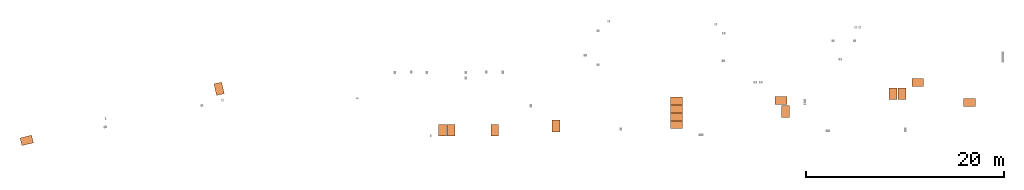
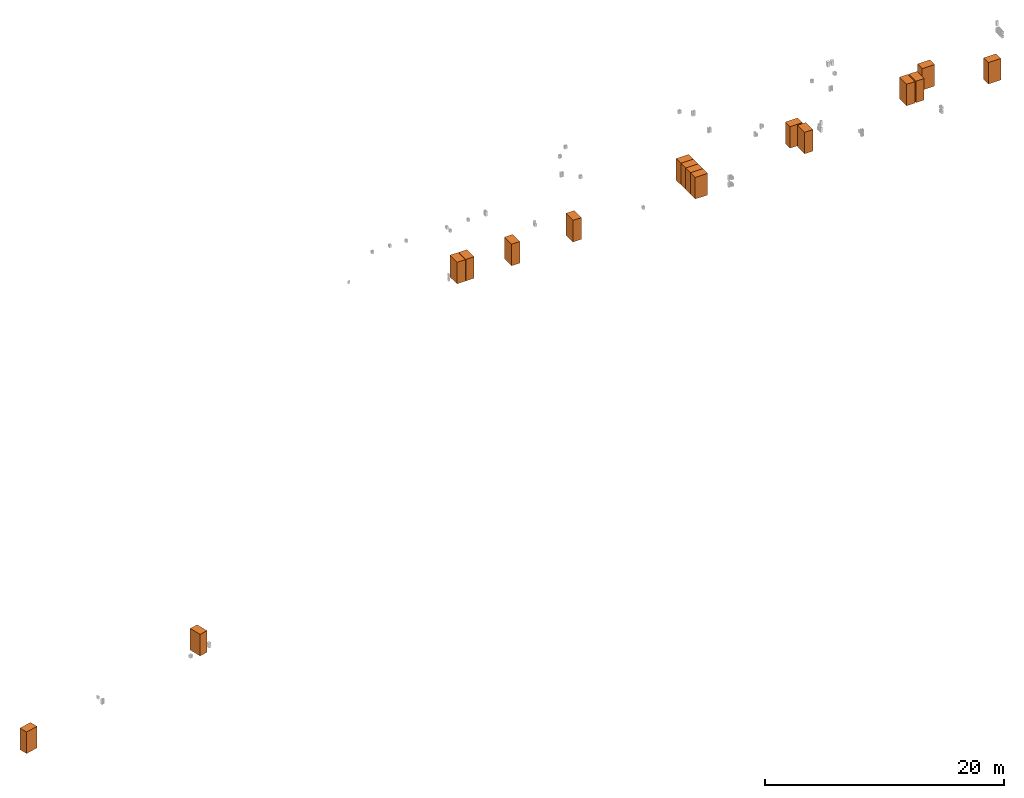
# Not in any storey, part 1 of 4: 16 proxies.
"""IFC2X3 model written with IfcOpenShell, lengths in millimetres."""

from ifc_helpers import new_model, si_unit, derived_unit, direction, frame, origin, place, context, subcontext, project, spatial, faceted_brep, type_object, element, save


model = new_model("IFC2X3")

# Units and contexts
model_context = context("Model", 3, precision=0.01, world=origin(), true_north=direction((6.12303176911189e-17, 1.0)))
body_context = subcontext(model_context, "Body", "Model", "MODEL_VIEW")
ifc_project = project(units=[si_unit("LENGTHUNIT", "METRE", prefix="MILLI"), si_unit("AREAUNIT", "SQUARE_METRE"), si_unit("VOLUMEUNIT", "CUBIC_METRE"), si_unit("PLANEANGLEUNIT", "RADIAN"), si_unit("MASSUNIT", "GRAM", prefix="KILO"), derived_unit("MASSDENSITYUNIT", [(si_unit("MASSUNIT", "GRAM", prefix="KILO"), 1), (si_unit("LENGTHUNIT", "METRE"), -3)]), derived_unit("MOMENTOFINERTIAUNIT", [(si_unit("LENGTHUNIT", "METRE"), 4)]), si_unit("TIMEUNIT", "SECOND"), si_unit("FREQUENCYUNIT", "HERTZ"), si_unit("THERMODYNAMICTEMPERATUREUNIT", "DEGREE_CELSIUS"), derived_unit("THERMALTRANSMITTANCEUNIT", [(si_unit("MASSUNIT", "GRAM", prefix="KILO"), 1), (si_unit("THERMODYNAMICTEMPERATUREUNIT", "KELVIN"), -1), (si_unit("TIMEUNIT", "SECOND"), -3)]), derived_unit("VOLUMETRICFLOWRATEUNIT", [(si_unit("LENGTHUNIT", "METRE"), 3), (si_unit("TIMEUNIT", "SECOND"), -1)]), derived_unit("MASSFLOWRATEUNIT", [(si_unit("MASSUNIT", "GRAM", prefix="KILO"), 1), (si_unit("TIMEUNIT", "SECOND"), -1)]), derived_unit("ROTATIONALFREQUENCYUNIT", [(si_unit("TIMEUNIT", "SECOND"), -1)]), si_unit("ELECTRICCURRENTUNIT", "AMPERE"), si_unit("ELECTRICVOLTAGEUNIT", "VOLT"), si_unit("POWERUNIT", "WATT"), si_unit("FORCEUNIT", "NEWTON", prefix="KILO"), si_unit("ILLUMINANCEUNIT", "LUX"), si_unit("LUMINOUSFLUXUNIT", "LUMEN"), si_unit("LUMINOUSINTENSITYUNIT", "CANDELA"), derived_unit("USERDEFINED", [(si_unit("MASSUNIT", "GRAM", prefix="KILO"), -1), (si_unit("LENGTHUNIT", "METRE"), -2), (si_unit("TIMEUNIT", "SECOND"), 3), (si_unit("LUMINOUSFLUXUNIT", "LUMEN"), 1)]), derived_unit("LINEARVELOCITYUNIT", [(si_unit("LENGTHUNIT", "METRE"), 1), (si_unit("TIMEUNIT", "SECOND"), -1)]), si_unit("PRESSUREUNIT", "PASCAL"), derived_unit("USERDEFINED", [(si_unit("LENGTHUNIT", "METRE"), -2), (si_unit("MASSUNIT", "GRAM", prefix="KILO"), 1), (si_unit("TIMEUNIT", "SECOND"), -2)]), derived_unit("LINEARFORCEUNIT", [(si_unit("MASSUNIT", "GRAM", prefix="KILO"), 1), (si_unit("LENGTHUNIT", "METRE"), 1), (si_unit("TIMEUNIT", "SECOND"), -2), (si_unit("LENGTHUNIT", "METRE"), -1)]), derived_unit("PLANARFORCEUNIT", [(si_unit("MASSUNIT", "GRAM", prefix="KILO"), 1), (si_unit("LENGTHUNIT", "METRE"), 1), (si_unit("TIMEUNIT", "SECOND"), -2), (si_unit("LENGTHUNIT", "METRE"), -2)])], contexts=[model_context])

# Site
site_placement = place(None, frame((0.0, -0.00077364408347762, 0.0)))
site = spatial("IfcSite", under=ifc_project, at=site_placement, CompositionType="ELEMENT")

# Proxies
building_element_proxy_type_1 = type_object("IfcBuildingElementProxyType", PredefinedType="NOTDEFINED")
proxy_1_placement = place(site_placement, frame((-6495.69993250786, 11805.728165958, -4200.0)))
element("IfcBuildingElementProxy", 1, at=proxy_1_placement, inside=site, type_object=building_element_proxy_type_1, context=body_context, shape_type="Brep", body=[
    faceted_brep([(871.974554424364, 966.709812850611, 0.0), (777.239295998118, 1355.32946084967, 0.0), (871.974554424364, 966.709812850611, 2200.0), (777.239295998117, 1355.32946084967, 2200.0), (94.7352584262477, 777.239295998111, 2200.0), (0.0, 1165.85894399717, 2200.0), (94.7352584262477, 777.239295998109, 0.0), (0.0, 1165.85894399717, 0.0)], [[[0, 1, 2]], [[3, 2, 1]], [[4, 5, 6]], [[7, 6, 5]], [[7, 5, 1]], [[3, 1, 5]], [[0, 2, 6]], [[4, 6, 2]], [[5, 4, 3]], [[2, 3, 4]], [[7, 1, 6]], [[0, 6, 1]]]),
    faceted_brep([(1061.44507127686, 189.470516852489, 0.0), (871.974554424365, 966.709812850609, 0.0), (1061.44507127686, 189.470516852489, 2200.0), (871.974554424365, 966.709812850611, 2200.0), (284.205775278742, 0.0, 2200.0), (94.7352584262466, 777.23929599812, 2200.0), (284.205775278743, 0.0, 0.0), (94.7352584262477, 777.23929599812, 0.0)], [[[0, 1, 2]], [[3, 2, 1]], [[4, 5, 6]], [[7, 6, 5]], [[7, 5, 1]], [[3, 1, 5]], [[0, 2, 6]], [[4, 6, 2]], [[5, 4, 3]], [[2, 3, 4]], [[7, 1, 6]], [[0, 6, 1]]]),
])
building_element_proxy_type_2 = type_object("IfcBuildingElementProxyType", PredefinedType="NOTDEFINED")
proxy_2_placement = place(site_placement, frame((-26068.6076268077, 6738.45006749214, -4200.0)))
element("IfcBuildingElementProxy", 2, at=proxy_2_placement, inside=site, type_object=building_element_proxy_type_2, context=body_context, shape_type="Brep", body=[
    faceted_brep([(0.0, 777.239295998119, 0.0), (0.0, 777.239295998117, 2200.0), (388.619647999063, 871.974554424364, 0.0), (388.619647999063, 871.974554424364, 2200.0), (578.090164851556, 94.7352584262477, 0.0), (578.090164851552, 94.7352584262466, 2200.0), (189.470516852502, 0.0, 0.0), (189.470516852502, 0.0, 2200.0)], [[[0, 1, 2]], [[3, 2, 1]], [[4, 5, 6]], [[7, 6, 5]], [[7, 1, 6]], [[0, 6, 1]], [[4, 2, 5]], [[3, 5, 2]], [[1, 7, 3]], [[5, 3, 7]], [[0, 2, 6]], [[4, 6, 2]]]),
    faceted_brep([(388.619647999067, 871.974554424366, 0.0), (388.619647999059, 871.974554424364, 2200.0), (1165.85894399719, 1061.44507127686, 0.0), (1165.85894399719, 1061.44507127686, 2200.0), (1355.32946084967, 284.205775278743, 0.0), (1355.32946084967, 284.205775278743, 2200.0), (578.090164851565, 94.7352584262488, 0.0), (578.090164851561, 94.7352584262466, 2200.0)], [[[0, 1, 2]], [[3, 2, 1]], [[4, 5, 6]], [[7, 6, 5]], [[7, 1, 6]], [[0, 6, 1]], [[4, 2, 5]], [[3, 5, 2]], [[1, 7, 3]], [[5, 3, 7]], [[0, 2, 6]], [[4, 6, 2]]]),
])
building_element_proxy_type_3 = type_object("IfcBuildingElementProxyType", PredefinedType="NOTDEFINED")
proxy_3_placement = place(site_placement, frame((17049.99, 7700.0, 28400.0)))
element("IfcBuildingElementProxy", 3, at=proxy_3_placement, inside=site, type_object=building_element_proxy_type_3, context=body_context, shape_type="Brep", body=[
    faceted_brep([(0.0, 0.0, 2200.0), (0.0, 400.0, 2200.0), (0.0, 0.0, 0.0), (0.0, 400.0, 0.0), (800.0, 0.0, 0.0), (800.0, 400.0, 0.0), (800.0, 0.0, 2200.0), (800.0, 400.0, 2200.0)], [[[0, 1, 2]], [[3, 2, 1]], [[4, 5, 6]], [[7, 6, 5]], [[4, 6, 2]], [[0, 2, 6]], [[3, 1, 5]], [[7, 5, 1]], [[0, 6, 1]], [[7, 1, 6]], [[3, 5, 2]], [[4, 2, 5]]]),
    faceted_brep([(0.0, 400.0, 2200.0), (0.0, 1200.0, 2200.0), (0.0, 400.0, 0.0), (0.0, 1200.0, 0.0), (800.0, 400.0, 0.0), (800.0, 1200.0, 0.0), (800.0, 400.0, 2200.0), (800.0, 1200.0, 2200.0)], [[[0, 1, 2]], [[3, 2, 1]], [[4, 5, 6]], [[7, 6, 5]], [[4, 6, 2]], [[0, 2, 6]], [[3, 1, 5]], [[7, 5, 1]], [[0, 6, 1]], [[7, 1, 6]], [[3, 5, 2]], [[4, 2, 5]]]),
])
building_element_proxy_type_4 = type_object("IfcBuildingElementProxyType", PredefinedType="NOTDEFINED")
proxy_4_placement = place(site_placement, frame((21470.01, 7700.0, 28400.0)))
element("IfcBuildingElementProxy", 4, at=proxy_4_placement, inside=site, type_object=building_element_proxy_type_4, context=body_context, shape_type="Brep", body=[
    faceted_brep([(0.0, 0.0, 2200.0), (0.0, 400.0, 2200.0), (0.0, 0.0, 0.0), (0.0, 400.0, 0.0), (800.0, 0.0, 0.0), (800.0, 400.0, 0.0), (800.0, 0.0, 2200.0), (800.0, 400.0, 2200.0)], [[[0, 1, 2]], [[3, 2, 1]], [[4, 5, 6]], [[7, 6, 5]], [[4, 6, 2]], [[0, 2, 6]], [[3, 1, 5]], [[7, 5, 1]], [[0, 6, 1]], [[7, 1, 6]], [[3, 5, 2]], [[4, 2, 5]]]),
    faceted_brep([(0.0, 400.0, 2200.0), (0.0, 1200.0, 2200.0), (0.0, 400.0, 0.0), (0.0, 1200.0, 0.0), (800.0, 400.0, 0.0), (800.0, 1200.0, 0.0), (800.0, 400.0, 2200.0), (800.0, 1200.0, 2200.0)], [[[0, 1, 2]], [[3, 2, 1]], [[4, 5, 6]], [[7, 6, 5]], [[4, 6, 2]], [[0, 2, 6]], [[3, 1, 5]], [[7, 5, 1]], [[0, 6, 1]], [[7, 1, 6]], [[3, 5, 2]], [[4, 2, 5]]]),
])
building_element_proxy_type_5 = type_object("IfcBuildingElementProxyType", PredefinedType="NOTDEFINED")
proxy_5_placement = place(site_placement, frame((16199.99, 7700.0, 28400.0)))
element("IfcBuildingElementProxy", 5, at=proxy_5_placement, inside=site, type_object=building_element_proxy_type_5, context=body_context, shape_type="Brep", body=[
    faceted_brep([(0.0, 0.0, 2200.0), (0.0, 400.0, 2200.0), (0.0, 0.0, 0.0), (0.0, 400.0, 0.0), (800.0, 0.0, 0.0), (800.0, 400.0, 0.0), (800.0, 0.0, 2200.0), (800.0, 400.0, 2200.0)], [[[0, 1, 2]], [[3, 2, 1]], [[4, 5, 6]], [[7, 6, 5]], [[4, 6, 2]], [[0, 2, 6]], [[3, 1, 5]], [[7, 5, 1]], [[0, 6, 1]], [[7, 1, 6]], [[3, 5, 2]], [[4, 2, 5]]]),
    faceted_brep([(0.0, 400.0, 2200.0), (0.0, 1200.0, 2200.0), (0.0, 400.0, 0.0), (0.0, 1200.0, 0.0), (800.0, 400.0, 0.0), (800.0, 1200.0, 0.0), (800.0, 400.0, 2200.0), (800.0, 1200.0, 2200.0)], [[[0, 1, 2]], [[3, 2, 1]], [[4, 5, 6]], [[7, 6, 5]], [[4, 6, 2]], [[0, 2, 6]], [[3, 1, 5]], [[7, 5, 1]], [[0, 6, 1]], [[7, 1, 6]], [[3, 5, 2]], [[4, 2, 5]]]),
])
building_element_proxy_type_6 = type_object("IfcBuildingElementProxyType", PredefinedType="NOTDEFINED")
proxy_6_placement = place(site_placement, frame((69205.06, 10700.01, 28400.0)))
element("IfcBuildingElementProxy", 6, at=proxy_6_placement, inside=site, type_object=building_element_proxy_type_6, context=body_context, shape_type="Brep", body=[
    faceted_brep([(0.0, 800.0, 0.0), (0.0, 800.0, 2200.0), (400.0, 800.0, 0.0), (400.0, 800.0, 2200.0), (400.0, 0.0, 0.0), (400.0, 0.0, 2200.0), (0.0, 0.0, 0.0), (0.0, 0.0, 2200.0)], [[[0, 1, 2]], [[3, 2, 1]], [[4, 5, 6]], [[7, 6, 5]], [[7, 1, 6]], [[0, 6, 1]], [[4, 2, 5]], [[3, 5, 2]], [[7, 5, 1]], [[3, 1, 5]], [[0, 2, 6]], [[4, 6, 2]]]),
    faceted_brep([(400.0, 800.0, 0.0), (400.0, 800.0, 2200.0), (1200.0, 800.0, 0.0), (1200.0, 800.0, 2200.0), (1200.0, 0.0, 0.0), (1200.0, 0.0, 2200.0), (400.0, 0.0, 0.0), (400.0, 0.0, 2200.0)], [[[0, 1, 2]], [[3, 2, 1]], [[4, 5, 6]], [[7, 6, 5]], [[7, 1, 6]], [[0, 6, 1]], [[4, 2, 5]], [[3, 5, 2]], [[7, 5, 1]], [[3, 1, 5]], [[0, 2, 6]], [[4, 6, 2]]]),
])
building_element_proxy_type_7 = type_object("IfcBuildingElementProxyType", PredefinedType="NOTDEFINED")
proxy_7_placement = place(site_placement, frame((39620.11, 9250.0, 28400.0)))
element("IfcBuildingElementProxy", 7, at=proxy_7_placement, inside=site, type_object=building_element_proxy_type_7, context=body_context, shape_type="Brep", body=[
    faceted_brep([(1200.0, 0.0, 0.0), (1200.0, 0.0, 2200.0), (800.0, 0.0, 0.0), (800.0, 0.0, 2200.0), (800.0, 800.0, 0.0), (800.0, 800.0, 2200.0), (1200.0, 800.0, 0.0), (1200.0, 800.0, 2200.0)], [[[0, 1, 2]], [[3, 2, 1]], [[4, 5, 6]], [[7, 6, 5]], [[0, 6, 1]], [[7, 1, 6]], [[3, 5, 2]], [[4, 2, 5]], [[3, 1, 5]], [[7, 5, 1]], [[4, 6, 2]], [[0, 2, 6]]]),
    faceted_brep([(800.0, 0.0, 0.0), (800.0, 0.0, 2200.0), (0.0, 0.0, 0.0), (0.0, 0.0, 2200.0), (0.0, 800.0, 0.0), (0.0, 800.0, 2200.0), (800.0, 800.0, 0.0), (800.0, 800.0, 2200.0)], [[[0, 1, 2]], [[3, 2, 1]], [[4, 5, 6]], [[7, 6, 5]], [[0, 6, 1]], [[7, 1, 6]], [[3, 5, 2]], [[4, 2, 5]], [[3, 1, 5]], [[7, 5, 1]], [[4, 6, 2]], [[0, 2, 6]]]),
])
building_element_proxy_type_8 = type_object("IfcBuildingElementProxyType", PredefinedType="NOTDEFINED")
proxy_8_placement = place(site_placement, frame((39620.11, 10050.0, 28400.0)))
element("IfcBuildingElementProxy", 8, at=proxy_8_placement, inside=site, type_object=building_element_proxy_type_8, context=body_context, shape_type="Brep", body=[
    faceted_brep([(1200.0, 0.0, 0.0), (1200.0, 0.0, 2200.0), (800.0, 0.0, 0.0), (800.0, 0.0, 2200.0), (800.0, 800.0, 0.0), (800.0, 800.0, 2200.0), (1200.0, 800.0, 0.0), (1200.0, 800.0, 2200.0)], [[[0, 1, 2]], [[3, 2, 1]], [[4, 5, 6]], [[7, 6, 5]], [[0, 6, 1]], [[7, 1, 6]], [[3, 5, 2]], [[4, 2, 5]], [[3, 1, 5]], [[7, 5, 1]], [[4, 6, 2]], [[0, 2, 6]]]),
    faceted_brep([(800.0, 0.0, 0.0), (800.0, 0.0, 2200.0), (0.0, 0.0, 0.0), (0.0, 0.0, 2200.0), (0.0, 800.0, 0.0), (0.0, 800.0, 2200.0), (800.0, 800.0, 0.0), (800.0, 800.0, 2200.0)], [[[0, 1, 2]], [[3, 2, 1]], [[4, 5, 6]], [[7, 6, 5]], [[0, 6, 1]], [[7, 1, 6]], [[3, 5, 2]], [[4, 2, 5]], [[3, 1, 5]], [[7, 5, 1]], [[4, 6, 2]], [[0, 2, 6]]]),
])
building_element_proxy_type_9 = type_object("IfcBuildingElementProxyType", PredefinedType="NOTDEFINED")
proxy_9_placement = place(site_placement, frame((39620.11, 10850.0, 28400.0)))
element("IfcBuildingElementProxy", 9, at=proxy_9_placement, inside=site, type_object=building_element_proxy_type_9, context=body_context, shape_type="Brep", body=[
    faceted_brep([(1200.0, 0.0, 0.0), (1200.0, 0.0, 2200.0), (800.0, 0.0, 0.0), (800.0, 0.0, 2200.0), (800.0, 800.0, 0.0), (800.0, 800.0, 2200.0), (1200.0, 800.0, 0.0), (1200.0, 800.0, 2200.0)], [[[0, 1, 2]], [[3, 2, 1]], [[4, 5, 6]], [[7, 6, 5]], [[0, 6, 1]], [[7, 1, 6]], [[3, 5, 2]], [[4, 2, 5]], [[3, 1, 5]], [[7, 5, 1]], [[4, 6, 2]], [[0, 2, 6]]]),
    faceted_brep([(800.0, 0.0, 0.0), (800.0, 0.0, 2200.0), (0.0, 0.0, 0.0), (0.0, 0.0, 2200.0), (0.0, 800.0, 0.0), (0.0, 800.0, 2200.0), (800.0, 800.0, 0.0), (800.0, 800.0, 2200.0)], [[[0, 1, 2]], [[3, 2, 1]], [[4, 5, 6]], [[7, 6, 5]], [[0, 6, 1]], [[7, 1, 6]], [[3, 5, 2]], [[4, 2, 5]], [[3, 1, 5]], [[7, 5, 1]], [[4, 6, 2]], [[0, 2, 6]]]),
])
building_element_proxy_type_10 = type_object("IfcBuildingElementProxyType", PredefinedType="NOTDEFINED")
proxy_10_placement = place(site_placement, frame((62599.99, 11380.0, 28400.0)))
element("IfcBuildingElementProxy", 10, at=proxy_10_placement, inside=site, type_object=building_element_proxy_type_10, context=body_context, shape_type="Brep", body=[
    faceted_brep([(0.0, 0.0, 2200.0), (0.0, 400.0, 2200.0), (0.0, 0.0, 0.0), (0.0, 400.0, 0.0), (800.0, 0.0, 0.0), (800.0, 400.0, 0.0), (800.0, 0.0, 2200.0), (800.0, 400.0, 2200.0)], [[[0, 1, 2]], [[3, 2, 1]], [[4, 5, 6]], [[7, 6, 5]], [[4, 6, 2]], [[0, 2, 6]], [[3, 1, 5]], [[7, 5, 1]], [[0, 6, 1]], [[7, 1, 6]], [[3, 5, 2]], [[4, 2, 5]]]),
    faceted_brep([(0.0, 400.0, 2200.0), (0.0, 1200.0, 2200.0), (0.0, 400.0, 0.0), (0.0, 1200.0, 0.0), (800.0, 400.0, 0.0), (800.0, 1200.0, 0.0), (800.0, 400.0, 2200.0), (800.0, 1200.0, 2200.0)], [[[0, 1, 2]], [[3, 2, 1]], [[4, 5, 6]], [[7, 6, 5]], [[4, 6, 2]], [[0, 2, 6]], [[3, 1, 5]], [[7, 5, 1]], [[0, 6, 1]], [[7, 1, 6]], [[3, 5, 2]], [[4, 2, 5]]]),
])
building_element_proxy_type_11 = type_object("IfcBuildingElementProxyType", PredefinedType="NOTDEFINED")
proxy_11_placement = place(site_placement, frame((61699.99, 11380.0, 28400.0)))
element("IfcBuildingElementProxy", 11, at=proxy_11_placement, inside=site, type_object=building_element_proxy_type_11, context=body_context, shape_type="Brep", body=[
    faceted_brep([(0.0, 0.0, 2200.0), (0.0, 400.0, 2200.0), (0.0, 0.0, 0.0), (0.0, 400.0, 0.0), (800.0, 0.0, 0.0), (800.0, 400.0, 0.0), (800.0, 0.0, 2200.0), (800.0, 400.0, 2200.0)], [[[0, 1, 2]], [[3, 2, 1]], [[4, 5, 6]], [[7, 6, 5]], [[4, 6, 2]], [[0, 2, 6]], [[3, 1, 5]], [[7, 5, 1]], [[0, 6, 1]], [[7, 1, 6]], [[3, 5, 2]], [[4, 2, 5]]]),
    faceted_brep([(0.0, 400.0, 2200.0), (0.0, 1200.0, 2200.0), (0.0, 400.0, 0.0), (0.0, 1200.0, 0.0), (800.0, 400.0, 0.0), (800.0, 1200.0, 0.0), (800.0, 400.0, 2200.0), (800.0, 1200.0, 2200.0)], [[[0, 1, 2]], [[3, 2, 1]], [[4, 5, 6]], [[7, 6, 5]], [[4, 6, 2]], [[0, 2, 6]], [[3, 1, 5]], [[7, 5, 1]], [[0, 6, 1]], [[7, 1, 6]], [[3, 5, 2]], [[4, 2, 5]]]),
])
building_element_proxy_type_12 = type_object("IfcBuildingElementProxyType", PredefinedType="NOTDEFINED")
proxy_12_placement = place(site_placement, frame((27649.99, 8135.0, 28400.0)))
element("IfcBuildingElementProxy", 12, at=proxy_12_placement, inside=site, type_object=building_element_proxy_type_12, context=body_context, shape_type="Brep", body=[
    faceted_brep([(0.0, 0.0, 2200.0), (0.0, 400.0, 2200.0), (0.0, 0.0, 0.0), (0.0, 400.0, 0.0), (800.0, 0.0, 0.0), (800.0, 400.0, 0.0), (800.0, 0.0, 2200.0), (800.0, 400.0, 2200.0)], [[[0, 1, 2]], [[3, 2, 1]], [[4, 5, 6]], [[7, 6, 5]], [[4, 6, 2]], [[0, 2, 6]], [[3, 1, 5]], [[7, 5, 1]], [[0, 6, 1]], [[7, 1, 6]], [[3, 5, 2]], [[4, 2, 5]]]),
    faceted_brep([(0.0, 400.0, 2200.0), (0.0, 1200.0, 2200.0), (0.0, 400.0, 0.0), (0.0, 1200.0, 0.0), (800.0, 400.0, 0.0), (800.0, 1200.0, 0.0), (800.0, 400.0, 2200.0), (800.0, 1200.0, 2200.0)], [[[0, 1, 2]], [[3, 2, 1]], [[4, 5, 6]], [[7, 6, 5]], [[4, 6, 2]], [[0, 2, 6]], [[3, 1, 5]], [[7, 5, 1]], [[0, 6, 1]], [[7, 1, 6]], [[3, 5, 2]], [[4, 2, 5]]]),
])
building_element_proxy_type_13 = type_object("IfcBuildingElementProxyType", PredefinedType="NOTDEFINED")
proxy_13_placement = place(site_placement, frame((39620.11, 8450.0, 28400.0)))
element("IfcBuildingElementProxy", 13, at=proxy_13_placement, inside=site, type_object=building_element_proxy_type_13, context=body_context, shape_type="Brep", body=[
    faceted_brep([(1200.0, 0.0, 0.0), (1200.0, 0.0, 2200.0), (800.0, 0.0, 0.0), (800.0, 0.0, 2200.0), (800.0, 800.0, 0.0), (800.0, 800.0, 2200.0), (1200.0, 800.0, 0.0), (1200.0, 800.0, 2200.0)], [[[0, 1, 2]], [[3, 2, 1]], [[4, 5, 6]], [[7, 6, 5]], [[0, 6, 1]], [[7, 1, 6]], [[3, 5, 2]], [[4, 2, 5]], [[3, 1, 5]], [[7, 5, 1]], [[4, 6, 2]], [[0, 2, 6]]]),
    faceted_brep([(800.0, 0.0, 0.0), (800.0, 0.0, 2200.0), (0.0, 0.0, 0.0), (0.0, 0.0, 2200.0), (0.0, 800.0, 0.0), (0.0, 800.0, 2200.0), (800.0, 800.0, 0.0), (800.0, 800.0, 2200.0)], [[[0, 1, 2]], [[3, 2, 1]], [[4, 5, 6]], [[7, 6, 5]], [[0, 6, 1]], [[7, 1, 6]], [[3, 5, 2]], [[4, 2, 5]], [[3, 1, 5]], [[7, 5, 1]], [[4, 6, 2]], [[0, 2, 6]]]),
])
building_element_proxy_type_14 = type_object("IfcBuildingElementProxyType", PredefinedType="NOTDEFINED")
proxy_14_placement = place(site_placement, frame((50835.01, 9575.0, 28400.0)))
element("IfcBuildingElementProxy", 14, at=proxy_14_placement, inside=site, type_object=building_element_proxy_type_14, context=body_context, shape_type="Brep", body=[
    faceted_brep([(800.0, 800.0, 0.0), (800.0, 1200.0, 0.0), (800.0, 800.0, 2200.0), (800.0, 1200.0, 2200.0), (0.0, 800.0, 2200.0), (0.0, 1200.0, 2200.0), (0.0, 800.0, 0.0), (0.0, 1200.0, 0.0)], [[[0, 1, 2]], [[3, 2, 1]], [[4, 5, 6]], [[7, 6, 5]], [[7, 5, 1]], [[3, 1, 5]], [[0, 2, 6]], [[4, 6, 2]], [[4, 2, 5]], [[3, 5, 2]], [[7, 1, 6]], [[0, 6, 1]]]),
    faceted_brep([(800.0, 0.0, 0.0), (800.0, 800.0, 0.0), (800.0, 0.0, 2200.0), (800.0, 800.0, 2200.0), (0.0, 0.0, 2200.0), (0.0, 800.0, 2200.0), (0.0, 0.0, 0.0), (0.0, 800.0, 0.0)], [[[0, 1, 2]], [[3, 2, 1]], [[4, 5, 6]], [[7, 6, 5]], [[7, 5, 1]], [[3, 1, 5]], [[0, 2, 6]], [[4, 6, 2]], [[4, 2, 5]], [[3, 5, 2]], [[7, 1, 6]], [[0, 6, 1]]]),
])
building_element_proxy_type_15 = type_object("IfcBuildingElementProxyType", PredefinedType="NOTDEFINED")
proxy_15_placement = place(site_placement, frame((50190.01, 10900.0, 28400.0)))
element("IfcBuildingElementProxy", 15, at=proxy_15_placement, inside=site, type_object=building_element_proxy_type_15, context=body_context, shape_type="Brep", body=[
    faceted_brep([(1200.0, 0.0, 0.0), (1200.0, 0.0, 2200.0), (800.0, 0.0, 0.0), (800.0, 0.0, 2200.0), (800.0, 800.0, 0.0), (800.0, 800.0, 2200.0), (1200.0, 800.0, 0.0), (1200.0, 800.0, 2200.0)], [[[0, 1, 2]], [[3, 2, 1]], [[4, 5, 6]], [[7, 6, 5]], [[0, 6, 1]], [[7, 1, 6]], [[3, 5, 2]], [[4, 2, 5]], [[3, 1, 5]], [[7, 5, 1]], [[4, 6, 2]], [[0, 2, 6]]]),
    faceted_brep([(800.0, 0.0, 0.0), (800.0, 0.0, 2200.0), (0.0, 0.0, 0.0), (0.0, 0.0, 2200.0), (0.0, 800.0, 0.0), (0.0, 800.0, 2200.0), (800.0, 800.0, 0.0), (800.0, 800.0, 2200.0)], [[[0, 1, 2]], [[3, 2, 1]], [[4, 5, 6]], [[7, 6, 5]], [[0, 6, 1]], [[7, 1, 6]], [[3, 5, 2]], [[4, 2, 5]], [[3, 1, 5]], [[7, 5, 1]], [[4, 6, 2]], [[0, 2, 6]]]),
])
building_element_proxy_type_16 = type_object("IfcBuildingElementProxyType", PredefinedType="NOTDEFINED")
proxy_16_placement = place(site_placement, frame((63980.0, 12700.0, 28400.0)))
element("IfcBuildingElementProxy", 16, at=proxy_16_placement, inside=site, type_object=building_element_proxy_type_16, context=body_context, shape_type="Brep", body=[
    faceted_brep([(1200.0, 0.0, 0.0), (1200.0, 0.0, 2200.0), (800.0, 0.0, 0.0), (800.0, 0.0, 2200.0), (800.0, 800.0, 0.0), (800.0, 800.0, 2200.0), (1200.0, 800.0, 0.0), (1200.0, 800.0, 2200.0)], [[[0, 1, 2]], [[3, 2, 1]], [[4, 5, 6]], [[7, 6, 5]], [[0, 6, 1]], [[7, 1, 6]], [[3, 5, 2]], [[4, 2, 5]], [[3, 1, 5]], [[7, 5, 1]], [[4, 6, 2]], [[0, 2, 6]]]),
    faceted_brep([(800.0, 0.0, 0.0), (800.0, 0.0, 2200.0), (0.0, 0.0, 0.0), (0.0, 0.0, 2200.0), (0.0, 800.0, 0.0), (0.0, 800.0, 2200.0), (800.0, 800.0, 0.0), (800.0, 800.0, 2200.0)], [[[0, 1, 2]], [[3, 2, 1]], [[4, 5, 6]], [[7, 6, 5]], [[0, 6, 1]], [[7, 1, 6]], [[3, 5, 2]], [[4, 2, 5]], [[3, 1, 5]], [[7, 5, 1]], [[4, 6, 2]], [[0, 2, 6]]]),
])

save(model, "model.ifc")
